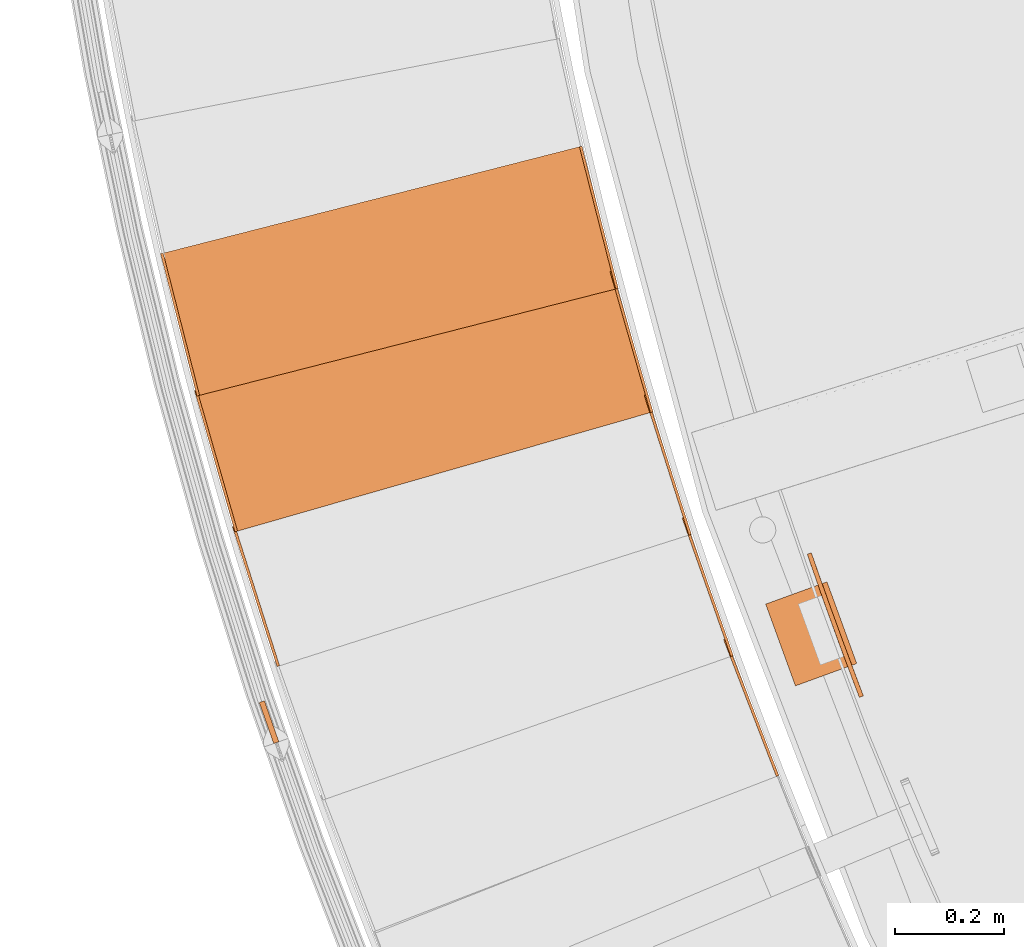
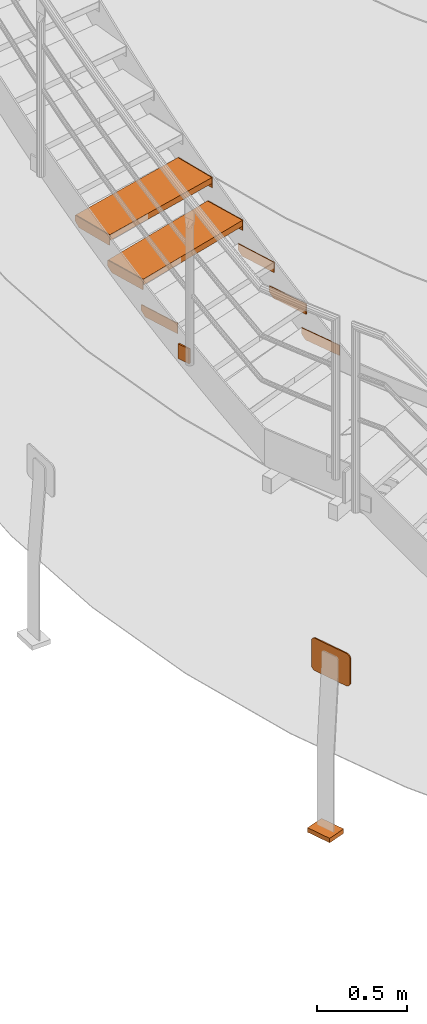
# One storey, part 51 of 126: 13 proxies.
"""IFC2X3 building model written with IfcOpenShell, lengths in millimetres."""

from ifc_helpers import new_model, si_unit, origin, origin_with_axes, place, context, project, spatial, faceted_brep, material, element, save


model = new_model("IFC2X3")

# Units and contexts
context_of_model_1 = context(None, 3, precision=0.1, world=origin())
context_of_model_2 = context(None, 3, precision=0.1, world=origin())
ifc_project = project(units=[si_unit("LENGTHUNIT", "METRE", prefix="MILLI"), si_unit("AREAUNIT", "SQUARE_METRE", prefix="CENTI"), si_unit("VOLUMEUNIT", "CUBIC_METRE", prefix="CENTI"), si_unit("MASSUNIT", "GRAM", prefix="KILO")], contexts=[context_of_model_1, context_of_model_2])

# Site, building, storey
site_placement = place(None, origin_with_axes())
site = spatial("IfcSite", under=ifc_project, at=site_placement, CompositionType="ELEMENT")
building_placement = place(site_placement, origin_with_axes())
building = spatial("IfcBuilding", under=site, at=building_placement, CompositionType="ELEMENT")
storey_placement = place(building_placement, origin_with_axes())
storey = spatial("IfcBuildingStorey", under=building, at=storey_placement, CompositionType="ELEMENT")

# Proxies
ifc_material_1 = material(Name="S235JRG2")
proxy_1_placement = place(storey_placement, origin_with_axes())
element("IfcBuildingElementProxy", 1, at=proxy_1_placement, inside=storey, material=ifc_material_1, context=context_of_model_2, shape_type="Brep", body=[
    faceted_brep([(546.5564, 5051.2976, 2874.51), (551.2218, 5053.0959, 2874.51), (551.2218, 5053.0959, 2944.51), (546.5564, 5051.2976, 2944.51), (449.4451, 5303.2289, 2944.51), (454.1105, 5305.0273, 2944.51), (454.1105, 5305.0273, 2904.51), (449.4451, 5303.2289, 2904.51), (460.2353, 5275.2365, 2874.51), (464.9007, 5277.0349, 2874.51)], [[[0, 1, 2, 3]], [[4, 5, 6, 7]], [[0, 8, 9, 1]], [[1, 9, 6, 5, 2]], [[2, 5, 4, 3]], [[0, 3, 4, 7, 8]], [[6, 9, 8, 7]]]),
])
proxy_2_placement = place(storey_placement, origin_with_axes())
element("IfcBuildingElementProxy", 2, at=proxy_2_placement, inside=storey, material=ifc_material_1, context=context_of_model_2, shape_type="Brep", body=[
    faceted_brep([(462.85, 5272.1055, 3047.67), (467.5663, 5273.7658, 3047.67), (467.5663, 5273.7658, 3117.67), (462.85, 5272.1055, 3117.67), (373.196, 5526.786, 3117.67), (377.9123, 5528.4463, 3117.67), (377.9123, 5528.4463, 3077.67), (373.196, 5526.786, 3077.67), (383.1576, 5498.4882, 3047.67), (387.8739, 5500.1485, 3047.67)], [[[0, 1, 2, 3]], [[4, 5, 6, 7]], [[0, 8, 9, 1]], [[1, 9, 6, 5, 2]], [[2, 5, 4, 3]], [[0, 3, 4, 7, 8]], [[6, 9, 8, 7]]]),
])
proxy_3_placement = place(storey_placement, origin_with_axes())
element("IfcBuildingElementProxy", 3, at=proxy_3_placement, inside=storey, material=ifc_material_1, context=context_of_model_2, shape_type="Brep", body=[
    faceted_brep([(385.679, 5495.2816, 3220.83), (390.4421, 5496.8023, 3220.83), (390.4421, 5496.8023, 3290.83), (385.679, 5495.2816, 3290.83), (303.56, 5752.4906, 3290.83), (308.3232, 5754.0113, 3290.83), (308.3232, 5754.0113, 3250.83), (303.56, 5752.4906, 3250.83), (312.6844, 5723.9118, 3220.83), (317.4475, 5725.4325, 3220.83)], [[[0, 1, 2, 3]], [[4, 5, 6, 7]], [[0, 8, 9, 1]], [[1, 9, 6, 5, 2]], [[2, 5, 4, 3]], [[0, 3, 4, 7, 8]], [[6, 9, 8, 7]]]),
])
proxy_4_placement = place(storey_placement, origin_with_axes())
element("IfcBuildingElementProxy", 4, at=proxy_4_placement, inside=storey, material=ifc_material_1, context=context_of_model_2, shape_type="Brep", body=[
    faceted_brep([(-371.6586, 5253.4868, 3220.83), (-366.8955, 5255.0076, 3220.83), (-366.8955, 5255.0076, 3290.83), (-371.6586, 5253.4868, 3290.83), (-453.7776, 5510.6958, 3290.83), (-449.0145, 5512.2166, 3290.83), (-449.0145, 5512.2166, 3250.83), (-453.7776, 5510.6958, 3250.83), (-444.6533, 5482.1171, 3220.83), (-439.8902, 5483.6378, 3220.83)], [[[0, 1, 2, 3]], [[4, 5, 6, 7]], [[0, 8, 9, 1]], [[1, 9, 6, 5, 2]], [[2, 5, 4, 3]], [[0, 3, 4, 7, 8]], [[6, 9, 8, 7]]]),
])
proxy_5_placement = place(storey_placement, origin_with_axes())
element("IfcBuildingElementProxy", 5, at=proxy_5_placement, inside=storey, material=ifc_material_1, context=context_of_model_2, shape_type="Brep", body=[
    faceted_brep([(-444.2103, 5502.6134, 3423.99), (-444.2103, 5502.6134, 3463.99), (-518.7231, 5762.128, 3463.99), (-518.7231, 5762.128, 3423.99), (315.1103, 5720.6324, 3423.99), (240.5975, 5980.147, 3423.99), (240.5975, 5980.147, 3463.99), (315.1103, 5720.6324, 3463.99)], [[[0, 1, 2, 3]], [[4, 5, 6, 7]], [[0, 4, 7, 1]], [[1, 7, 6, 2]], [[2, 6, 5, 3]], [[3, 5, 4, 0]]]),
])
proxy_6_placement = place(storey_placement, origin_with_axes())
element("IfcBuildingElementProxy", 6, at=proxy_6_placement, inside=storey, material=ifc_material_1, context=context_of_model_2, shape_type="Brep", body=[
    faceted_brep([(315.1103, 5720.6324, 3393.99), (319.9161, 5722.0122, 3393.99), (319.9161, 5722.0122, 3463.99), (315.1103, 5720.6324, 3463.99), (240.5975, 5980.147, 3463.99), (245.4033, 5981.5269, 3463.99), (245.4033, 5981.5269, 3423.99), (240.5975, 5980.147, 3423.99), (248.8767, 5951.312, 3393.99), (253.6825, 5952.6919, 3393.99)], [[[0, 1, 2, 3]], [[4, 5, 6, 7]], [[0, 8, 9, 1]], [[1, 9, 6, 5, 2]], [[2, 5, 4, 3]], [[0, 3, 4, 7, 8]], [[6, 9, 8, 7]]]),
])
proxy_7_placement = place(storey_placement, origin_with_axes())
element("IfcBuildingElementProxy", 7, at=proxy_7_placement, inside=storey, material=ifc_material_1, context=context_of_model_2, shape_type="Brep", body=[
    faceted_brep([(-449.0161, 5501.2335, 3393.99), (-444.2103, 5502.6134, 3393.99), (-444.2103, 5502.6134, 3463.99), (-449.0161, 5501.2335, 3463.99), (-523.5289, 5760.7481, 3463.99), (-518.7231, 5762.128, 3463.99), (-518.7231, 5762.128, 3423.99), (-523.5289, 5760.7481, 3423.99), (-515.2497, 5731.9132, 3393.99), (-510.4439, 5733.293, 3393.99)], [[[0, 1, 2, 3]], [[4, 5, 6, 7]], [[0, 8, 9, 1]], [[1, 9, 6, 5, 2]], [[2, 5, 4, 3]], [[0, 3, 4, 7, 8]], [[6, 9, 8, 7]]]),
])
proxy_8_placement = place(storey_placement, origin_with_axes())
element("IfcBuildingElementProxy", 8, at=proxy_8_placement, inside=storey, material=ifc_material_1, context=context_of_model_2, shape_type="Brep", body=[
    faceted_brep([(-514.2036, 5752.3875, 3597.15), (-514.2036, 5752.3875, 3637.15), (-581.0457, 6013.9829, 3637.15), (-581.0457, 6013.9829, 3597.15), (251.205, 5947.9626, 3597.15), (184.3629, 6209.558, 3597.15), (184.3629, 6209.558, 3637.15), (251.205, 5947.9626, 3637.15)], [[[0, 1, 2, 3]], [[4, 5, 6, 7]], [[0, 4, 7, 1]], [[1, 7, 6, 2]], [[2, 6, 5, 3]], [[3, 5, 4, 0]]]),
])
proxy_9_placement = place(storey_placement, origin_with_axes())
element("IfcBuildingElementProxy", 9, at=proxy_9_placement, inside=storey, material=ifc_material_1, context=context_of_model_2, shape_type="Brep", body=[
    faceted_brep([(251.205, 5947.9626, 3567.15), (256.0494, 5949.2004, 3567.15), (256.0494, 5949.2004, 3637.15), (251.205, 5947.9626, 3637.15), (184.3629, 6209.558, 3637.15), (189.2073, 6210.7958, 3637.15), (189.2073, 6210.7958, 3597.15), (184.3629, 6209.558, 3597.15), (191.7898, 6180.4918, 3567.15), (196.6342, 6181.7296, 3567.15)], [[[0, 1, 2, 3]], [[4, 5, 6, 7]], [[0, 8, 9, 1]], [[1, 9, 6, 5, 2]], [[2, 5, 4, 3]], [[0, 3, 4, 7, 8]], [[6, 9, 8, 7]]]),
])
proxy_10_placement = place(storey_placement, origin_with_axes())
element("IfcBuildingElementProxy", 10, at=proxy_10_placement, inside=storey, material=ifc_material_1, context=context_of_model_2, shape_type="Brep", body=[
    faceted_brep([(-519.048, 5751.1497, 3567.15), (-514.2036, 5752.3875, 3567.15), (-514.2036, 5752.3875, 3637.15), (-519.048, 5751.1497, 3637.15), (-585.8901, 6012.7451, 3637.15), (-581.0457, 6013.9829, 3637.15), (-581.0457, 6013.9829, 3597.15), (-585.8901, 6012.7451, 3597.15), (-578.4632, 5983.6789, 3567.15), (-573.6188, 5984.9167, 3567.15)], [[[0, 1, 2, 3]], [[4, 5, 6, 7]], [[0, 8, 9, 1]], [[1, 9, 6, 5, 2]], [[2, 5, 4, 3]], [[0, 3, 4, 7, 8]], [[6, 9, 8, 7]]]),
])
ifc_material_2 = material(Name="STAHL")
proxy_11_placement = place(storey_placement, origin_with_axes())
element("IfcBuildingElementProxy", 11, at=proxy_11_placement, inside=storey, material=ifc_material_2, Name="profile", context=context_of_model_2, shape_type="Brep", body=[
    faceted_brep([(615.3, 5450.5, 704.7), (613.9, 5454.5, 701.2), (606.3, 5451.9, 701.2), (607.9, 5447.5, 705.0), (616.9, 5445.8, 707.5), (609.7, 5442.3, 707.9), (618.8, 5440.2, 709.4), (611.5, 5437.1, 709.5), (690.8, 5219.2, 709.4), (698.1, 5222.5, 709.5), (696.1, 5227.7, 710.0), (670.4, 5296.4, 710.0), (645.3, 5365.3, 710.0), (620.8, 5434.5, 710.0), (613.3, 5431.9, 710.0), (637.7, 5362.6, 710.0), (662.9, 5293.6, 710.0), (688.6, 5224.8, 710.0), (704.9, 5204.5, 697.0), (703.7, 5207.8, 701.2), (696.2, 5205.0, 701.2), (697.6, 5201.4, 696.5), (705.9, 5202.0, 692.0), (698.6, 5198.7, 691.0), (706.6, 5200.2, 686.0), (699.2, 5197.2, 685.5), (699.4, 5196.8, 680.0), (699.4, 5196.8, 520.0), (699.1, 5197.3, 514.0), (706.6, 5200.1, 514.5), (706.8, 5199.6, 520.0), (706.8, 5199.6, 680.0), (607.7, 5447.9, 495.3), (606.3, 5451.9, 498.8), (613.9, 5454.5, 498.8), (615.4, 5450.1, 495.0), (609.3, 5443.2, 492.5), (617.2, 5444.9, 492.1), (611.3, 5437.6, 490.6), (619.0, 5439.7, 490.5), (690.6, 5219.6, 490.5), (688.6, 5224.8, 490.0), (662.9, 5293.6, 490.0), (637.7, 5362.6, 490.0), (613.3, 5431.9, 490.0), (620.8, 5434.5, 490.0), (645.3, 5365.3, 490.0), (670.4, 5296.4, 490.0), (696.1, 5227.7, 490.0), (698.3, 5222.0, 490.6), (697.5, 5201.7, 503.0), (696.2, 5205.0, 498.8), (703.7, 5207.8, 498.8), (705.0, 5204.3, 503.5), (698.5, 5199.1, 508.0), (706.1, 5201.6, 509.0), (692.5, 5214.5, 492.1), (700.4, 5216.5, 492.5), (694.5, 5209.4, 495.0), (702.2, 5211.8, 495.3), (603.7, 5459.7, 686.0), (611.2, 5462.4, 685.5), (611.0, 5462.8, 680.0), (611.0, 5462.8, 520.0), (611.2, 5462.3, 514.0), (603.6, 5459.8, 514.5), (603.5, 5460.2, 520.0), (603.5, 5460.2, 680.0), (604.1, 5458.3, 509.0), (611.8, 5460.5, 508.0), (605.1, 5455.6, 503.5), (612.7, 5457.9, 503.0), (700.0, 5217.4, 707.9), (692.9, 5213.6, 707.5), (702.0, 5212.2, 705.0), (694.7, 5208.9, 704.7), (611.7, 5460.9, 691.0), (604.3, 5457.9, 692.0), (612.6, 5458.2, 696.5), (605.2, 5455.3, 697.0)], [[[0, 1, 2, 3]], [[4, 0, 3, 5]], [[6, 4, 5, 7]], [[8, 9, 10, 11, 12, 13, 6, 7, 14, 15, 16, 17]], [[18, 19, 20, 21]], [[22, 18, 21, 23]], [[24, 22, 23, 25]], [[26, 27, 28, 29, 30, 31, 24, 25]], [[32, 33, 34, 35]], [[36, 32, 35, 37]], [[38, 36, 37, 39]], [[40, 41, 42, 43, 44, 38, 39, 45, 46, 47, 48, 49]], [[50, 51, 52, 53]], [[54, 50, 53, 55]], [[28, 54, 55, 29]], [[56, 40, 49, 57]], [[58, 56, 57, 59]], [[51, 58, 59, 52]], [[60, 61, 62, 63, 64, 65, 66, 67]], [[68, 65, 64, 69]], [[70, 68, 69, 71]], [[33, 70, 71, 34]], [[72, 9, 8, 73]], [[74, 72, 73, 75]], [[19, 74, 75, 20]], [[76, 61, 60, 77]], [[78, 76, 77, 79]], [[1, 78, 79, 2]], [[31, 30, 29, 55, 53, 52, 59, 57, 49, 48, 47, 46, 45, 39, 37, 35, 34, 71, 69, 64, 63, 62, 61, 76, 78, 1, 0, 4, 6, 13, 12, 11, 10, 9, 72, 74, 19, 18, 22, 24]], [[27, 26, 25, 23, 21, 20, 75, 73, 8, 17, 16, 15, 14, 7, 5, 3, 2, 79, 77, 60, 67, 66, 65, 68, 70, 33, 32, 36, 38, 44, 43, 42, 41, 40, 56, 58, 51, 50, 54, 28]]]),
])
proxy_12_placement = place(storey_placement, origin_with_axes())
element("IfcBuildingElementProxy", 12, at=proxy_12_placement, inside=storey, material=ifc_material_2, Name="profile", context=context_of_model_2, shape_type="Brep", body=[
    faceted_brep([(694.5, 5259.1, -530.0), (581.7, 5218.0, -530.0), (527.0, 5368.4, -530.0), (639.8, 5409.4, -530.0), (581.7, 5218.0, -500.0), (527.0, 5368.4, -500.0), (694.5, 5259.1, -500.0), (639.8, 5409.4, -500.0)], [[[0, 1, 2, 3]], [[1, 4, 5, 2]], [[4, 6, 7, 5]], [[6, 0, 3, 7]], [[1, 0, 6, 4]], [[7, 3, 2, 5]]]),
])
proxy_13_placement = place(storey_placement, origin_with_axes())
element("IfcBuildingElementProxy", 13, at=proxy_13_placement, inside=storey, material=ifc_material_1, Name="HANDLAUF", context=context_of_model_2, shape_type="Brep", body=[
    faceted_brep([(-404.3392, 5187.3702, 3105.1049), (-394.9072, 5190.6925, 3105.1049), (-368.3285, 5115.2368, 3105.1049), (-377.7605, 5111.9144, 3105.1049), (-404.3392, 5187.3702, 3205.1049), (-377.7605, 5111.9144, 3205.1049), (-368.3285, 5115.2368, 3205.1049), (-394.9072, 5190.6925, 3205.1049)], [[[0, 1, 2, 3]], [[4, 5, 6, 7]], [[0, 4, 7, 1]], [[1, 7, 6, 2]], [[2, 6, 5, 3]], [[3, 5, 4, 0]]]),
])

save(model, "model.ifc")
